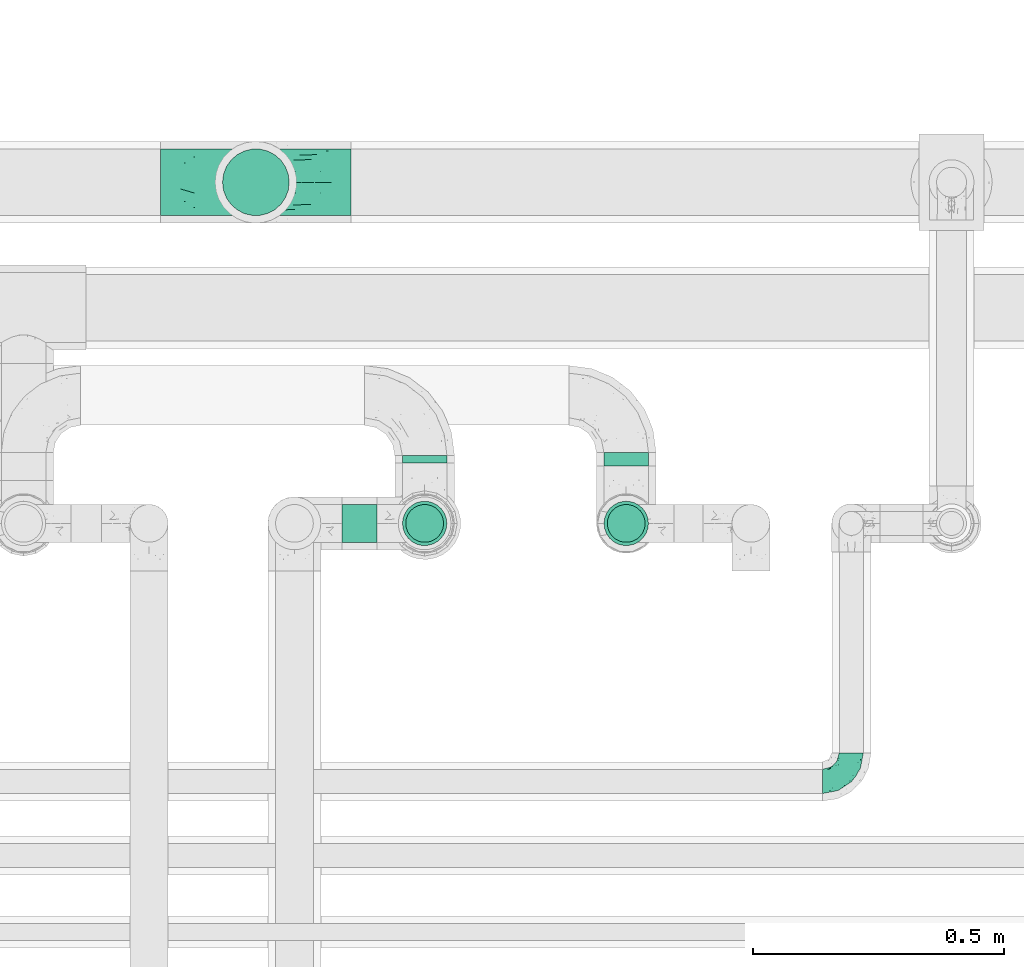
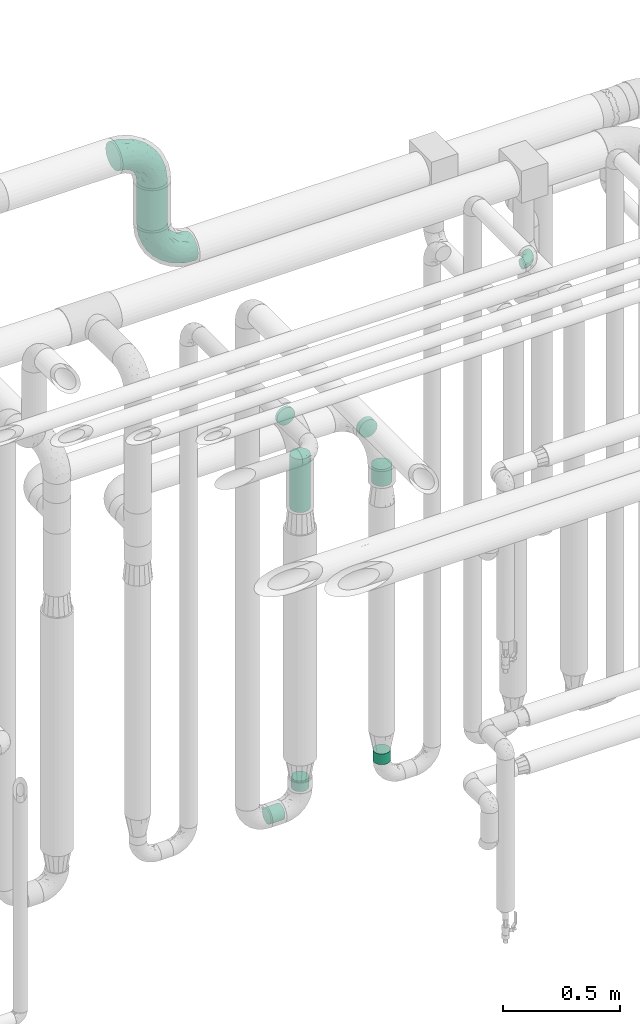
# One storey, part 710 of 827: 8 flow segments, 3 flow fittings.
"""IFC2X3 building model written with IfcOpenShell, lengths in millimetres."""

from ifc_helpers import new_model, entity, si_unit, converted_unit, derived_unit, direction, frame, origin, origin_2d_with_axis, place, context, subcontext, project, spatial, circle, extrude, faceted_brep, source, transform, mapped, material, type_object, type_shapes, element, save


model = new_model("IFC2X3")

# Units and contexts
model_context = context("Model", 3, precision=0.01, world=origin(), true_north=direction((6.12303176911189e-17, 1.0)))
body_context = subcontext(model_context, "Body", "Model", "MODEL_VIEW")
ifc_project = project(units=[si_unit("LENGTHUNIT", "METRE", prefix="MILLI"), si_unit("AREAUNIT", "SQUARE_METRE"), si_unit("VOLUMEUNIT", "CUBIC_METRE"), converted_unit("PLANEANGLEUNIT", "DEGREE", entity("IfcRatioMeasure", 0.0174532925199433), si_unit("PLANEANGLEUNIT", "RADIAN"), dimensions=[0, 0, 0, 0, 0, 0, 0]), si_unit("MASSUNIT", "GRAM", prefix="KILO"), derived_unit("MASSDENSITYUNIT", [(si_unit("MASSUNIT", "GRAM", prefix="KILO"), 1), (si_unit("LENGTHUNIT", "METRE"), -3)]), derived_unit("MOMENTOFINERTIAUNIT", [(si_unit("LENGTHUNIT", "METRE"), 4)]), si_unit("TIMEUNIT", "SECOND"), si_unit("FREQUENCYUNIT", "HERTZ"), si_unit("THERMODYNAMICTEMPERATUREUNIT", "DEGREE_CELSIUS"), derived_unit("THERMALTRANSMITTANCEUNIT", [(si_unit("MASSUNIT", "GRAM", prefix="KILO"), 1), (si_unit("THERMODYNAMICTEMPERATUREUNIT", "KELVIN"), -1), (si_unit("TIMEUNIT", "SECOND"), -3)]), derived_unit("VOLUMETRICFLOWRATEUNIT", [(si_unit("LENGTHUNIT", "METRE"), 3), (si_unit("TIMEUNIT", "SECOND"), -1)]), derived_unit("MASSFLOWRATEUNIT", [(si_unit("MASSUNIT", "GRAM", prefix="KILO"), 1), (si_unit("TIMEUNIT", "SECOND"), -1)]), derived_unit("ROTATIONALFREQUENCYUNIT", [(si_unit("TIMEUNIT", "SECOND"), -1)]), si_unit("ELECTRICCURRENTUNIT", "AMPERE"), si_unit("ELECTRICVOLTAGEUNIT", "VOLT"), si_unit("POWERUNIT", "WATT"), si_unit("FORCEUNIT", "NEWTON", prefix="KILO"), si_unit("ILLUMINANCEUNIT", "LUX"), si_unit("LUMINOUSFLUXUNIT", "LUMEN"), si_unit("LUMINOUSINTENSITYUNIT", "CANDELA"), derived_unit("USERDEFINED", [(si_unit("MASSUNIT", "GRAM", prefix="KILO"), -1), (si_unit("LENGTHUNIT", "METRE"), -2), (si_unit("TIMEUNIT", "SECOND"), 3), (si_unit("LUMINOUSFLUXUNIT", "LUMEN"), 1)]), derived_unit("LINEARVELOCITYUNIT", [(si_unit("LENGTHUNIT", "METRE"), 1), (si_unit("TIMEUNIT", "SECOND"), -1)]), si_unit("PRESSUREUNIT", "PASCAL"), derived_unit("USERDEFINED", [(si_unit("LENGTHUNIT", "METRE"), -2), (si_unit("MASSUNIT", "GRAM", prefix="KILO"), 1), (si_unit("TIMEUNIT", "SECOND"), -2)]), derived_unit("LINEARFORCEUNIT", [(si_unit("MASSUNIT", "GRAM", prefix="KILO"), 1), (si_unit("LENGTHUNIT", "METRE"), 1), (si_unit("TIMEUNIT", "SECOND"), -2), (si_unit("LENGTHUNIT", "METRE"), -1)]), derived_unit("PLANARFORCEUNIT", [(si_unit("MASSUNIT", "GRAM", prefix="KILO"), 1), (si_unit("LENGTHUNIT", "METRE"), 1), (si_unit("TIMEUNIT", "SECOND"), -2), (si_unit("LENGTHUNIT", "METRE"), -2)])], contexts=[model_context])

# Site, building, storey
site_placement = place(None, origin())
site = spatial("IfcSite", under=ifc_project, at=site_placement, CompositionType="ELEMENT")
building_placement = place(site_placement, origin())
building = spatial("IfcBuilding", under=site, at=building_placement, CompositionType="ELEMENT")
storey_placement = place(building_placement, frame((0.0, 0.0, 28200.0)))
storey = spatial("IfcBuildingStorey", under=building, at=storey_placement, Name="08", CompositionType="ELEMENT", Elevation=28200.0)

# Flow segments
pipe_segment_type_1 = type_object("IfcPipeSegmentType", PredefinedType="NOTDEFINED")
flow_segment_1_placement = place(storey_placement, frame((57842.95, 18112.0, 3090.0)))
element("IfcFlowSegment", 1, at=flow_segment_1_placement, inside=storey, type_object=pipe_segment_type_1, context=body_context, shape_type="SweptSolid", body=[
    extrude(circle(Radius=66.5, at=origin_2d_with_axis()), frame((68.1, 68.1, 0.0), z_axis=(0.0, 0.0, 1.0), x_axis=(-1.0, 0.0, 0.0)), (0.0, 0.0, 1.0), 219.743188805708),
])
pipe_segment_type_2 = type_object("IfcPipeSegmentType", PredefinedType="NOTDEFINED")
flow_segment_2_placement = place(storey_placement, frame((58201.72, 17620.0, 2254.15)))
element("IfcFlowSegment", 2, at=flow_segment_2_placement, inside=storey, type_object=pipe_segment_type_2, context=body_context, shape_type="SweptSolid", body=[
    extrude(circle(Radius=44.25, at=origin_2d_with_axis()), frame((45.85, 0.0, 45.85), z_axis=(0.0, 1.0, 0.0), x_axis=(-1.0, 0.0, 0.0)), (0.0, 0.0, 1.0), 15.0961141089939),
])
flow_segment_3_placement = place(storey_placement, frame((58201.72, 17454.15, 1902.45)))
element("IfcFlowSegment", 3, at=flow_segment_3_placement, inside=storey, type_object=pipe_segment_type_2, context=body_context, shape_type="SweptSolid", body=[
    extrude(circle(Radius=44.25, at=origin_2d_with_axis()), frame((45.85, 45.85, 0.0)), (0.0, 0.0, 1.0), 277.547222472813),
])
flow_segment_4_placement = place(storey_placement, frame((58082.89, 17460.65, 310.65)))
element("IfcFlowSegment", 4, at=flow_segment_4_placement, inside=storey, type_object=pipe_segment_type_2, context=body_context, shape_type="SweptSolid", body=[
    extrude(circle(Radius=37.75, at=origin_2d_with_axis()), frame((0.0, 39.35, 39.35), z_axis=(1.0, 0.0, 0.0), x_axis=(0.0, -1.0, 0.0)), (0.0, 0.0, 1.0), 69.6845769329227),
])
for number, where in (
    (5, (58208.22, 17460.65, 445.0)),
    (6, (58610.04, 17460.65, 445.0)),
):
    element("IfcFlowSegment", number, at=place(storey_placement, frame(where)), inside=storey, type_object=pipe_segment_type_2, context=body_context, shape_type="SweptSolid", body=[
        extrude(circle(Radius=37.75, at=origin_2d_with_axis()), frame((39.35, 39.35, 0.0), z_axis=(0.0, 0.0, 1.0), x_axis=(-1.0, 0.0, 0.0)), (0.0, 0.0, 1.0), 55.0000000000005),
    ])
flow_segment_5_placement = place(storey_placement, frame((58603.54, 17614.0, 2054.15)))
element("IfcFlowSegment", 7, at=flow_segment_5_placement, inside=storey, type_object=pipe_segment_type_2, context=body_context, shape_type="SweptSolid", body=[
    extrude(circle(Radius=44.25, at=origin_2d_with_axis()), frame((45.85, 0.0, 45.85), z_axis=(0.0, 1.0, 0.0), x_axis=(-1.0, 0.0, 0.0)), (0.0, 0.0, 1.0), 27.0961141089868),
])
flow_segment_6_placement = place(storey_placement, frame((58603.54, 17454.15, 1898.17)))
element("IfcFlowSegment", 8, at=flow_segment_6_placement, inside=storey, type_object=pipe_segment_type_2, context=body_context, shape_type="SweptSolid", body=[
    extrude(circle(Radius=44.25, at=origin_2d_with_axis()), frame((45.85, 45.85, 0.0)), (0.0, 0.0, 1.0), 87.8307333425285),
])

# Flow fittings
ifc_material = material()
pipe_fitting_type_1 = type_object("IfcPipeFittingType", Name="ADSK_2", PredefinedType="NOTDEFINED", material=ifc_material)
shared_shape_1 = source(origin(), body_context, "Body", "Brep", [
    faceted_brep([(-190.0, 33.25, -57.59), (-190.0, 17.21, -64.23), (-190.0, 0.0, -66.5), (-190.0, -17.21, -64.23), (-190.0, -33.25, -57.59), (-190.0, -47.02, -47.02), (-190.0, -57.59, -33.25), (-190.0, -64.23, -17.21), (-190.0, -66.5, 0.0), (-190.0, -64.23, 17.21), (-190.0, -57.59, 33.25), (-190.0, -47.02, 47.02), (-190.0, -33.25, 57.59), (-190.0, -17.21, 64.23), (-190.0, 0.0, 66.5), (-190.0, 17.21, 64.23), (-190.0, 33.25, 57.59), (-190.0, 47.02, 47.02), (-190.0, 57.59, 33.25), (-190.0, 64.23, 17.21), (-190.0, 66.5, 0.0), (-190.0, 64.23, -17.21), (-190.0, 57.59, -33.25), (-190.0, 47.02, -47.02), (0.0, 190.0, -66.5), (-17.21, 190.0, -64.23), (-33.25, 190.0, -57.59), (-47.02, 190.0, -47.02), (-57.59, 190.0, -33.25), (-64.23, 190.0, -17.21), (-66.5, 190.0, 0.0), (-64.23, 190.0, 17.21), (-57.59, 190.0, 33.25), (-47.02, 190.0, 47.02), (-33.25, 190.0, 57.59), (-17.21, 190.0, 64.23), (0.0, 190.0, 66.5), (17.21, 190.0, 64.23), (33.25, 190.0, 57.59), (47.02, 190.0, 47.02), (57.59, 190.0, 33.25), (64.23, 190.0, 17.21), (66.5, 190.0, 0.0), (64.23, 190.0, -17.21), (57.59, 190.0, -33.25), (47.02, 190.0, -47.02), (33.25, 190.0, -57.59), (17.21, 190.0, -64.23), (-28.55, 147.02, 62.42), (-13.57, 135.63, 66.28), (-140.38, -49.33, 38.23), (-80.14, -30.55, 35.23), (-124.14, -33.9, 50.4), (-141.11, -22.46, 60.31), (-81.84, -6.19, 57.13), (-101.3, 6.38, 65.03), (-125.04, -54.28, 21.95), (-139.96, -61.57, 0.0), (-30.59, -6.47, 21.28), (-47.5, -23.27, 0.0), (-8.63, 8.63, 0.0), (-101.64, 52.37, 61.01), (-147.02, 28.55, 62.42), (-107.01, 35.47, 64.88), (-72.79, -35.94, 16.05), (-91.84, -46.98, 0.0), (-42.05, -7.73, 34.33), (-4.24, 27.9, 35.0), (-46.26, 0.22, 45.96), (-148.38, -6.74, 65.57), (-135.63, 13.57, 66.28), (-58.81, 143.49, 42.9), (-64.43, 158.86, 27.32), (33.87, 124.03, 50.39), (-24.86, 95.88, 66.5), (-6.38, 101.3, 65.03), (-68.44, 29.45, 65.52), (-33.12, 50.38, 63.42), (-47.55, 58.11, 66.37), (-68.78, 157.93, 15.75), (-78.73, 128.81, 21.25), (-145.19, 58.3, 42.81), (-126.57, 73.12, 34.22), (-158.86, 64.43, 27.32), (-157.93, 68.78, 15.75), (-73.06, 126.96, 34.0), (-99.23, 99.23, 24.99), (-94.51, 94.51, 37.44), (-160.28, 41.89, 53.91), (-151.84, 72.54, 0.0), (-128.81, 78.73, 21.25), (-117.41, 90.09, 0.0), (7.42, 29.34, 16.05), (36.05, 72.53, 15.16), (23.27, 47.5, 0.0), (30.73, 80.34, 35.12), (61.57, 139.96, 0.0), (62.07, 150.38, 13.25), (46.98, 91.84, 0.0), (22.46, 141.08, 60.31), (6.16, 81.82, 57.15), (-39.4, 100.2, 64.86), (54.07, 123.33, 21.27), (49.32, 140.35, 38.22), (-83.36, -19.52, 48.87), (6.74, 148.38, 65.57), (-85.07, 81.39, 53.88), (-123.92, 51.92, 55.31), (-90.09, 117.41, 0.0), (-72.54, 151.84, 0.0), (-101.92, 101.92, 11.85), (-42.36, 157.28, 54.02), (-54.08, 118.94, 55.5), (-1.97, 47.81, 48.28), (22.27, 83.36, 46.49), (-79.1, 73.18, 59.88), (-73.69, 63.3, 64.01), (-96.26, 24.55, 66.5), (-73.56, 111.53, 44.32), (-111.08, 72.88, 45.21), (-31.39, 31.39, 56.96), (-71.89, 12.15, 62.21), (-42.48, 117.92, 61.28), (-157.28, 42.36, -54.02), (-72.79, -35.94, -16.05), (-44.48, -10.39, -33.14), (-30.59, -6.47, -21.28), (-101.3, 6.38, -65.03), (-148.38, -6.74, -65.57), (-135.63, 13.57, -66.28), (-157.93, 68.78, -15.75), (-128.81, 78.73, -21.25), (-158.86, 64.43, -27.32), (-147.02, 28.55, -62.42), (-100.2, 39.4, -64.86), (-95.88, 24.86, -66.5), (-150.3, -62.06, -13.27), (-101.92, 101.92, -11.85), (-143.49, 58.81, -42.9), (6.74, 148.38, -65.57), (-13.57, 135.63, -66.28), (-52.37, 101.64, -61.01), (-81.39, 85.07, -53.88), (-51.92, 123.92, -55.31), (-124.14, -33.9, -50.4), (-81.84, -6.19, -57.13), (-78.6, -18.73, -47.44), (-140.38, -49.33, -38.23), (-24.55, 96.26, -66.5), (-35.47, 107.01, -64.88), (-28.55, 147.02, -62.42), (-80.14, -30.55, -35.23), (-123.37, -54.04, -21.36), (-64.43, 158.86, -27.32), (-68.78, 157.93, -15.75), (-73.18, 79.1, -59.88), (-63.3, 73.69, -64.01), (-29.45, 68.44, -65.52), (-50.38, 33.12, -63.42), (-58.11, 47.55, -66.37), (-78.73, 128.81, -21.25), (-99.23, 99.23, -24.99), (-126.96, 73.06, -34.0), (-94.51, 94.51, -37.44), (-58.3, 145.19, -42.81), (-73.12, 126.57, -34.22), (-118.94, 54.08, -55.5), (-41.89, 160.28, -53.91), (22.46, 141.08, -60.31), (6.16, 81.82, -57.15), (-6.38, 101.3, -65.03), (33.87, 124.03, -50.39), (54.35, 125.32, -21.97), (35.86, 72.99, -16.69), (49.34, 140.46, -38.23), (7.54, 29.16, -15.21), (-141.11, -22.46, -60.31), (30.73, 80.34, -35.12), (22.8, 84.14, -46.35), (-4.38, 23.43, -29.89), (5.33, 47.62, -41.81), (-111.53, 73.56, -44.32), (-72.88, 111.08, -45.21), (-48.51, 2.91, -49.35), (-20.15, 28.66, -49.63), (-27.46, 10.86, -41.59), (-12.16, 71.91, -62.22), (2.48, 58.84, -50.8), (-117.92, 42.48, -61.28), (-31.39, 31.39, -56.96)], [[[0, 1, 2, 3, 4, 5, 6, 7, 8, 9, 10, 11, 12, 13, 14, 15, 16, 17, 18, 19, 20, 21, 22, 23]], [[24, 25, 26, 27, 28, 29, 30, 31, 32, 33, 34, 35, 36, 37, 38, 39, 40, 41, 42, 43, 44, 45, 46, 47]], [[35, 48, 49]], [[50, 51, 52]], [[53, 54, 55]], [[56, 10, 9]], [[9, 8, 57]], [[58, 59, 60]], [[56, 50, 10]], [[61, 62, 63]], [[64, 65, 59]], [[58, 64, 59]], [[12, 11, 52]], [[66, 67, 68]], [[52, 53, 12]], [[69, 70, 14]], [[71, 32, 72]], [[73, 39, 38]], [[49, 74, 75]], [[62, 16, 15]], [[14, 70, 15]], [[72, 32, 31]], [[13, 69, 14]], [[76, 77, 78]], [[79, 80, 72]], [[81, 82, 83]], [[62, 15, 70]], [[20, 19, 84]], [[85, 86, 87]], [[81, 17, 88]], [[89, 90, 91]], [[19, 83, 84]], [[16, 88, 17]], [[85, 71, 72]], [[58, 60, 92]], [[49, 36, 35]], [[93, 92, 94]], [[35, 34, 48]], [[92, 93, 95]], [[96, 97, 98]], [[73, 99, 100]], [[49, 101, 74]], [[102, 97, 40]], [[39, 73, 103]], [[95, 102, 103]], [[40, 39, 103]], [[12, 53, 13]], [[68, 54, 104]], [[42, 97, 96]], [[41, 97, 42]], [[99, 38, 37]], [[37, 36, 105]], [[61, 106, 107]], [[108, 80, 109]], [[10, 50, 11]], [[108, 91, 110]], [[109, 79, 30]], [[64, 51, 56]], [[71, 33, 32]], [[86, 110, 90]], [[92, 60, 94]], [[111, 34, 33]], [[71, 112, 111]], [[49, 48, 101]], [[9, 57, 56]], [[17, 81, 18]], [[65, 56, 57]], [[113, 114, 100]], [[75, 105, 49]], [[115, 61, 116]], [[58, 92, 67]], [[99, 73, 38]], [[70, 117, 63]], [[18, 83, 19]], [[71, 85, 118]], [[119, 107, 106]], [[83, 82, 90]], [[51, 50, 56]], [[52, 11, 50]], [[51, 64, 58]], [[56, 65, 64]], [[94, 98, 93]], [[67, 92, 95]], [[95, 114, 113]], [[68, 120, 54]], [[54, 53, 52]], [[69, 53, 55]], [[104, 51, 68]], [[121, 76, 55]], [[103, 73, 114]], [[102, 40, 103]], [[105, 99, 37]], [[75, 77, 100]], [[75, 100, 99]], [[100, 120, 113]], [[111, 48, 34]], [[115, 101, 122]], [[122, 101, 48]], [[101, 116, 78]], [[116, 63, 117]], [[78, 117, 76]], [[63, 62, 70]], [[88, 62, 107]], [[98, 102, 93]], [[95, 93, 102]], [[66, 68, 51]], [[113, 68, 67]], [[49, 105, 36]], [[99, 105, 75]], [[53, 69, 13]], [[70, 69, 55]], [[70, 55, 117]], [[61, 63, 116]], [[76, 117, 55]], [[116, 117, 78]], [[121, 55, 54]], [[76, 121, 77]], [[100, 77, 120]], [[75, 78, 77]], [[54, 120, 121]], [[77, 121, 120]], [[71, 111, 33]], [[111, 112, 122]], [[68, 113, 120]], [[95, 113, 67]], [[61, 115, 106]], [[62, 61, 107]], [[118, 112, 71]], [[119, 87, 82]], [[101, 115, 116]], [[112, 106, 115]], [[79, 72, 31]], [[72, 80, 85]], [[86, 85, 80]], [[118, 85, 87]], [[119, 118, 87]], [[112, 118, 106]], [[30, 79, 31]], [[109, 80, 79]], [[81, 83, 18]], [[84, 83, 90]], [[119, 82, 81]], [[86, 82, 87]], [[107, 119, 81]], [[118, 119, 106]], [[90, 89, 84]], [[20, 84, 89]], [[62, 88, 16]], [[81, 88, 107]], [[101, 78, 74]], [[78, 75, 74]], [[80, 108, 110]], [[82, 86, 90]], [[90, 110, 91]], [[80, 110, 86]], [[40, 97, 41]], [[98, 97, 102]], [[111, 122, 48]], [[115, 122, 112]], [[54, 52, 104]], [[51, 104, 52]], [[51, 58, 66]], [[67, 66, 58]], [[103, 114, 95]], [[100, 114, 73]], [[23, 123, 0]], [[124, 125, 126]], [[127, 128, 129]], [[130, 131, 132]], [[133, 134, 129]], [[129, 135, 127]], [[89, 130, 20]], [[8, 136, 57]], [[91, 131, 89]], [[59, 65, 124]], [[108, 137, 91]], [[132, 22, 21]], [[138, 23, 22]], [[139, 140, 24]], [[141, 142, 143]], [[144, 145, 146]], [[5, 144, 147]], [[140, 148, 149]], [[8, 7, 136]], [[138, 22, 132]], [[6, 5, 147]], [[141, 150, 149]], [[147, 151, 152]], [[152, 136, 6]], [[29, 153, 154]], [[125, 124, 151]], [[136, 65, 57]], [[155, 141, 156]], [[128, 3, 2]], [[126, 59, 124]], [[129, 134, 135]], [[157, 158, 159]], [[160, 161, 137]], [[1, 0, 133]], [[129, 2, 1]], [[162, 138, 132]], [[161, 163, 162]], [[154, 30, 29]], [[144, 5, 4]], [[153, 164, 165]], [[150, 26, 25]], [[166, 123, 138]], [[24, 47, 139]], [[24, 140, 25]], [[28, 153, 29]], [[26, 167, 27]], [[168, 169, 170]], [[140, 150, 25]], [[27, 164, 28]], [[46, 171, 168]], [[172, 98, 173]], [[59, 126, 60]], [[27, 167, 164]], [[44, 174, 45]], [[173, 98, 94]], [[175, 173, 94]], [[176, 144, 4]], [[171, 46, 45]], [[44, 43, 172]], [[43, 96, 172]], [[42, 96, 43]], [[144, 146, 151]], [[144, 176, 145]], [[177, 178, 174]], [[173, 175, 179]], [[44, 172, 174]], [[98, 172, 96]], [[1, 133, 129]], [[179, 180, 177]], [[109, 160, 108]], [[46, 168, 47]], [[176, 4, 3]], [[138, 162, 181]], [[182, 143, 142]], [[153, 165, 160]], [[94, 60, 175]], [[177, 172, 173]], [[151, 147, 144]], [[152, 6, 147]], [[128, 176, 3]], [[127, 158, 145]], [[127, 145, 176]], [[183, 184, 185]], [[65, 152, 124]], [[151, 124, 152]], [[177, 174, 172]], [[171, 45, 174]], [[169, 168, 171]], [[139, 168, 170]], [[178, 177, 180]], [[186, 157, 170]], [[187, 169, 178]], [[126, 179, 175]], [[123, 133, 0]], [[155, 134, 188]], [[188, 134, 133]], [[134, 156, 159]], [[156, 149, 148]], [[159, 148, 157]], [[149, 150, 140]], [[167, 150, 143]], [[60, 126, 175]], [[125, 179, 126]], [[129, 128, 2]], [[176, 128, 127]], [[168, 139, 47]], [[140, 139, 170]], [[140, 170, 148]], [[141, 149, 156]], [[157, 148, 170]], [[156, 148, 159]], [[186, 170, 169]], [[157, 186, 158]], [[145, 158, 189]], [[127, 159, 158]], [[169, 189, 186]], [[158, 186, 189]], [[180, 179, 185]], [[173, 179, 177]], [[187, 184, 189]], [[178, 171, 174]], [[187, 178, 180]], [[169, 171, 178]], [[184, 180, 185]], [[189, 169, 187]], [[138, 123, 23]], [[123, 166, 188]], [[141, 155, 142]], [[150, 141, 143]], [[181, 166, 138]], [[182, 163, 165]], [[134, 155, 156]], [[166, 142, 155]], [[130, 132, 21]], [[132, 131, 162]], [[161, 162, 131]], [[181, 162, 163]], [[182, 181, 163]], [[166, 181, 142]], [[20, 130, 21]], [[89, 131, 130]], [[164, 153, 28]], [[154, 153, 160]], [[182, 165, 164]], [[161, 165, 163]], [[143, 182, 164]], [[181, 182, 142]], [[160, 109, 154]], [[30, 154, 109]], [[150, 167, 26]], [[164, 167, 143]], [[134, 159, 135]], [[159, 127, 135]], [[131, 91, 137]], [[165, 161, 160]], [[160, 137, 108]], [[131, 137, 161]], [[6, 136, 7]], [[65, 136, 152]], [[183, 189, 184]], [[146, 183, 125]], [[146, 125, 151]], [[179, 125, 185]], [[123, 188, 133]], [[155, 188, 166]], [[180, 184, 187]], [[185, 125, 183]], [[146, 145, 183]], [[189, 183, 145]]]),
])
type_shapes(pipe_fitting_type_1, [shared_shape_1])
for number, where, z_axis, x_axis, name in (
    (9, (57911.05, 18180.1, 2900.0), (0.0, 1.0, 0.0), (-1.0, 0.0, 0.0), "ADSK_2"),
    (10, (57911.05, 18180.1, 3499.74), (0.0, -1.0, 0.0), (0.0, 0.0, 1.0), "ADSK_2"),
):
    element("IfcFlowFitting", number, at=place(storey_placement, frame(where, z_axis=z_axis, x_axis=x_axis)), inside=storey, type_object=pipe_fitting_type_1, material=ifc_material, Name=name, ObjectType="ADSK_2", context=body_context, shape_type="MappedRepresentation", body=[
        mapped(shared_shape_1, transform((0.0, 0.0, 0.0), scale=1.0)),
    ])
pipe_fitting_type_2 = type_object("IfcPipeFittingType", Name="ADSK_1", PredefinedType="NOTDEFINED", material=ifc_material)
shared_shape_2 = source(origin(), body_context, "Body", "Brep", [
    faceted_brep([(-57.0, 12.07, -20.91), (-57.0, 6.25, -23.33), (-57.0, 0.0, -24.15), (-57.0, -6.25, -23.33), (-57.0, -12.08, -20.91), (-57.0, -17.08, -17.08), (-57.0, -20.91, -12.08), (-57.0, -23.33, -6.25), (-57.0, -24.15, 0.0), (-57.0, -23.33, 6.25), (-57.0, -20.91, 12.07), (-57.0, -17.08, 17.08), (-57.0, -12.08, 20.91), (-57.0, -6.25, 23.33), (-57.0, 0.0, 24.15), (-57.0, 6.25, 23.33), (-57.0, 12.07, 20.91), (-57.0, 17.08, 17.08), (-57.0, 20.91, 12.07), (-57.0, 23.33, 6.25), (-57.0, 24.15, 0.0), (-57.0, 23.33, -6.25), (-57.0, 20.91, -12.08), (-57.0, 17.08, -17.08), (0.0, 57.0, -24.15), (-6.25, 57.0, -23.33), (-12.07, 57.0, -20.91), (-17.08, 57.0, -17.08), (-20.91, 57.0, -12.08), (-23.33, 57.0, -6.25), (-24.15, 57.0, 0.0), (-23.33, 57.0, 6.25), (-20.91, 57.0, 12.07), (-17.08, 57.0, 17.08), (-12.07, 57.0, 20.91), (-6.25, 57.0, 23.33), (0.0, 57.0, 24.15), (6.25, 57.0, 23.33), (12.08, 57.0, 20.91), (17.08, 57.0, 17.08), (20.91, 57.0, 12.07), (23.33, 57.0, 6.25), (24.15, 57.0, 0.0), (23.33, 57.0, -6.25), (20.91, 57.0, -12.08), (17.08, 57.0, -17.08), (12.08, 57.0, -20.91), (6.25, 57.0, -23.33), (14.9, 21.14, 6.17), (13.61, 24.64, 12.48), (6.23, 8.95, 8.98), (-41.47, -21.06, 0.0), (-41.92, -18.38, 13.72), (-24.64, -13.61, 12.48), (-37.37, -13.24, 18.15), (-6.8, -4.93, 8.18), (-21.76, -15.19, 6.22), (-12.78, -9.18, 0.0), (-37.73, -20.51, 7.75), (-7.38, 7.38, 20.24), (-23.37, -4.26, 20.42), (-11.9, -3.19, 15.86), (-42.14, -8.7, 21.82), (13.24, 37.37, 18.15), (9.33, 23.53, 16.85), (4.26, 23.37, 20.42), (2.77, 10.92, 15.55), (-29.46, 0.91, 23.52), (-44.13, 20.56, 15.69), (-39.25, 26.33, 10.88), (-49.02, 22.92, 9.96), (-34.58, 23.87, 17.15), (-15.8, 6.8, 22.81), (-8.67, 20.47, 23.88), (-18.12, 12.9, 24.08), (-48.29, 14.92, 19.65), (-44.06, -2.85, 23.78), (-9.23, 48.95, 22.58), (-3.78, 42.74, 24.07), (-40.34, 4.26, 24.09), (-44.02, 26.14, 5.46), (-44.04, 9.88, 22.74), (-4.95, 16.87, 22.52), (-2.75, 1.43, 12.5), (-25.48, 40.98, 10.71), (20.51, 37.73, 7.75), (18.38, 41.92, 13.72), (8.7, 42.14, 21.82), (-25.95, -17.97, 0.0), (2.85, 44.06, 23.78), (21.06, 41.47, 0.0), (17.97, 25.95, 0.0), (-24.04, -9.27, 17.13), (-33.26, 33.26, 5.86), (-28.55, 40.57, 0.0), (-40.57, 28.55, 0.0), (-25.29, 47.19, 4.06), (-27.01, 31.1, 16.77), (-15.7, 43.95, 19.9), (-20.27, 45.22, 15.61), (-30.53, 31.98, 12.64), (-11.28, 38.33, 22.92), (-9.97, 27.88, 24.09), (-20.15, 30.26, 21.25), (-31.25, 11.75, 23.64), (-28.75, 7.23, 24.15), (-29.53, 18.06, 22.27), (-28.44, 24.21, 20.02), (-37.55, 17.7, 20.26), (-15.88, 29.25, 22.99), (-20.82, 20.82, 23.44), (-0.91, 29.46, 23.52), (-13.5, -7.67, 12.04), (1.49, 1.56, 5.16), (8.86, 10.35, 4.59), (0.38, -0.38, 0.0), (9.18, 12.78, 0.0), (-37.37, -13.24, -18.15), (8.86, 10.35, -4.59), (-45.22, 20.27, -15.61), (-43.95, 15.7, -19.9), (-38.33, 11.28, -22.92), (-48.95, 9.23, -22.58), (-47.19, 25.29, -4.06), (-33.26, 33.26, -5.86), (18.38, 41.92, -13.72), (-30.26, 20.15, -21.25), (2.85, 44.06, -23.78), (-4.26, 40.34, -24.09), (-40.98, 25.48, -10.71), (-41.92, -18.38, -13.72), (9.25, 23.5, -16.92), (4.26, 23.37, -20.42), (13.24, 37.37, -18.15), (-37.73, -20.51, -7.75), (-11.75, 31.25, -23.64), (-7.23, 28.75, -24.15), (-12.9, 18.12, -24.08), (8.7, 42.14, -21.82), (-44.06, -2.85, -23.78), (-6.8, 15.8, -22.81), (-20.47, 8.67, -23.88), (-24.64, -13.61, -12.48), (-42.74, 3.78, -24.07), (-18.06, 29.53, -22.27), (-24.21, 28.44, -20.02), (-27.88, 9.97, -24.09), (-31.1, 27.01, -16.77), (-26.14, 44.02, -5.46), (14.9, 21.14, -6.17), (20.51, 37.73, -7.75), (-9.88, 44.04, -22.74), (-20.56, 44.13, -15.69), (-21.76, -15.19, -6.22), (-13.5, -7.67, -12.04), (-24.14, -9.76, -16.74), (-11.9, -3.19, -15.86), (-14.92, 48.29, -19.65), (-23.37, -4.26, -20.42), (-0.91, 29.46, -23.52), (-26.33, 39.25, -10.88), (-23.87, 34.58, -17.15), (-42.14, -8.7, -21.82), (-22.92, 49.02, -9.96), (13.61, 24.64, -12.48), (-31.98, 30.53, -12.64), (-16.87, 4.95, -22.52), (-17.7, 37.55, -20.26), (-29.25, 15.88, -22.99), (-20.82, 20.82, -23.44), (-29.46, 0.91, -23.52), (-7.38, 7.38, -20.24), (2.77, 10.92, -15.55), (6.23, 8.95, -8.98), (-6.8, -4.93, -8.18), (-2.81, 1.41, -12.54), (1.49, 1.56, -5.16)], [[[0, 1, 2, 3, 4, 5, 6, 7, 8, 9, 10, 11, 12, 13, 14, 15, 16, 17, 18, 19, 20, 21, 22, 23]], [[24, 25, 26, 27, 28, 29, 30, 31, 32, 33, 34, 35, 36, 37, 38, 39, 40, 41, 42, 43, 44, 45, 46, 47]], [[48, 49, 50]], [[9, 8, 51]], [[52, 53, 54]], [[55, 56, 57]], [[10, 58, 52]], [[9, 58, 10]], [[59, 60, 61]], [[54, 12, 11]], [[54, 62, 12]], [[63, 39, 38]], [[64, 65, 66]], [[62, 60, 67]], [[68, 69, 70]], [[71, 69, 68]], [[72, 73, 74]], [[16, 75, 17]], [[13, 76, 14]], [[35, 77, 78]], [[14, 79, 15]], [[17, 68, 18]], [[14, 76, 79]], [[20, 19, 80]], [[70, 19, 18]], [[81, 15, 79]], [[15, 81, 16]], [[73, 72, 82]], [[66, 83, 50]], [[32, 31, 84]], [[85, 86, 49]], [[63, 87, 65]], [[56, 58, 88]], [[36, 89, 37]], [[85, 41, 40]], [[36, 35, 78]], [[90, 41, 85]], [[40, 39, 86]], [[12, 62, 13]], [[86, 85, 40]], [[48, 85, 49]], [[85, 91, 90]], [[87, 38, 37]], [[92, 60, 54]], [[80, 69, 93]], [[93, 94, 95]], [[10, 52, 11]], [[94, 96, 30]], [[97, 98, 99]], [[80, 93, 95]], [[100, 97, 84]], [[99, 98, 33]], [[101, 102, 78]], [[103, 101, 98]], [[96, 31, 30]], [[77, 98, 101]], [[77, 35, 34]], [[34, 33, 98]], [[9, 51, 58]], [[87, 63, 38]], [[104, 105, 74]], [[106, 103, 107]], [[106, 81, 104]], [[75, 68, 17]], [[108, 107, 71]], [[33, 32, 99]], [[109, 103, 110]], [[101, 109, 102]], [[89, 78, 111]], [[53, 52, 58]], [[54, 11, 52]], [[60, 62, 54]], [[88, 58, 51]], [[76, 62, 67]], [[53, 112, 92]], [[60, 59, 72]], [[39, 63, 86]], [[49, 86, 63]], [[89, 87, 37]], [[42, 41, 90]], [[111, 82, 65]], [[111, 65, 87]], [[65, 59, 66]], [[104, 81, 79]], [[75, 81, 108]], [[32, 84, 99]], [[97, 99, 84]], [[98, 97, 103]], [[106, 107, 108]], [[74, 102, 110]], [[111, 78, 102]], [[74, 110, 104]], [[74, 67, 72]], [[61, 92, 112]], [[66, 59, 61]], [[56, 53, 58]], [[66, 50, 49]], [[61, 112, 83]], [[66, 49, 64]], [[78, 89, 36]], [[87, 89, 111]], [[62, 76, 13]], [[79, 76, 67]], [[100, 93, 69]], [[96, 93, 84]], [[55, 113, 50]], [[113, 114, 50]], [[104, 79, 105]], [[106, 104, 110]], [[20, 80, 95]], [[85, 48, 91]], [[115, 114, 113]], [[116, 91, 48]], [[70, 80, 19]], [[93, 96, 94]], [[84, 31, 96]], [[103, 106, 110]], [[81, 106, 108]], [[103, 97, 107]], [[71, 107, 97]], [[71, 97, 100]], [[108, 71, 68]], [[79, 67, 105]], [[67, 74, 105]], [[115, 113, 57]], [[112, 56, 55]], [[56, 88, 57]], [[60, 72, 67]], [[82, 72, 59]], [[65, 82, 59]], [[82, 111, 73]], [[111, 102, 73]], [[102, 74, 73]], [[81, 75, 16]], [[68, 75, 108]], [[68, 70, 18]], [[80, 70, 69]], [[98, 77, 34]], [[78, 77, 101]], [[93, 100, 84]], [[71, 100, 69]], [[102, 109, 110]], [[101, 103, 109]], [[53, 92, 54]], [[61, 60, 92]], [[56, 112, 53]], [[83, 112, 55]], [[50, 83, 55]], [[61, 83, 66]], [[49, 63, 64]], [[65, 64, 63]], [[57, 113, 55]], [[114, 115, 116]], [[116, 48, 114]], [[48, 50, 114]], [[117, 5, 4]], [[116, 115, 118]], [[119, 120, 23]], [[121, 122, 120]], [[95, 123, 20]], [[0, 23, 120]], [[124, 95, 94]], [[125, 45, 44]], [[121, 120, 126]], [[24, 127, 128]], [[22, 21, 129]], [[0, 122, 1]], [[5, 117, 130]], [[131, 132, 133]], [[134, 88, 51]], [[135, 136, 137]], [[6, 5, 130]], [[46, 138, 47]], [[139, 3, 2]], [[140, 141, 137]], [[6, 134, 7]], [[134, 130, 142]], [[143, 2, 1]], [[144, 126, 145]], [[121, 146, 143]], [[147, 120, 119]], [[94, 148, 124]], [[149, 150, 91]], [[30, 29, 148]], [[151, 25, 128]], [[27, 152, 28]], [[134, 153, 88]], [[154, 155, 156]], [[27, 26, 157]], [[151, 26, 25]], [[155, 158, 156]], [[24, 47, 127]], [[1, 122, 143]], [[138, 132, 159]], [[160, 152, 161]], [[24, 128, 25]], [[46, 133, 138]], [[162, 117, 4]], [[148, 160, 124]], [[152, 160, 163]], [[154, 142, 155]], [[45, 125, 133]], [[133, 46, 45]], [[125, 164, 133]], [[51, 7, 134]], [[42, 90, 43]], [[165, 147, 129]], [[153, 134, 142]], [[43, 150, 44]], [[162, 4, 3]], [[141, 140, 166]], [[117, 162, 158]], [[163, 29, 28]], [[43, 90, 150]], [[123, 21, 20]], [[144, 151, 135]], [[157, 152, 27]], [[167, 145, 161]], [[23, 22, 119]], [[168, 126, 169]], [[121, 168, 146]], [[139, 143, 170]], [[142, 130, 117]], [[8, 7, 51]], [[134, 6, 130]], [[139, 162, 3]], [[170, 166, 158]], [[170, 158, 162]], [[158, 171, 156]], [[44, 150, 125]], [[91, 150, 90]], [[164, 125, 150]], [[132, 138, 133]], [[127, 138, 159]], [[131, 164, 172]], [[132, 171, 140]], [[135, 151, 128]], [[157, 151, 167]], [[22, 129, 119]], [[147, 119, 129]], [[120, 147, 126]], [[144, 145, 167]], [[137, 146, 169]], [[170, 143, 146]], [[137, 169, 135]], [[137, 159, 140]], [[171, 172, 156]], [[173, 174, 175]], [[156, 175, 154]], [[174, 57, 153]], [[132, 172, 171]], [[172, 164, 173]], [[143, 139, 2]], [[162, 139, 170]], [[138, 127, 47]], [[128, 127, 159]], [[165, 124, 160]], [[123, 124, 129]], [[149, 173, 164]], [[176, 174, 173]], [[135, 128, 136]], [[144, 135, 169]], [[150, 149, 164]], [[176, 118, 115]], [[149, 91, 116]], [[30, 148, 94]], [[163, 148, 29]], [[124, 123, 95]], [[129, 21, 123]], [[126, 144, 169]], [[151, 144, 167]], [[126, 147, 145]], [[161, 145, 147]], [[161, 147, 165]], [[167, 161, 152]], [[128, 159, 136]], [[159, 137, 136]], [[154, 153, 142]], [[132, 140, 159]], [[174, 176, 57]], [[57, 88, 153]], [[166, 140, 171]], [[158, 166, 171]], [[166, 170, 141]], [[170, 146, 141]], [[146, 137, 141]], [[151, 157, 26]], [[152, 157, 167]], [[152, 163, 28]], [[148, 163, 160]], [[120, 122, 0]], [[143, 122, 121]], [[124, 165, 129]], [[161, 165, 160]], [[146, 168, 169]], [[121, 126, 168]], [[142, 117, 155]], [[158, 155, 117]], [[175, 156, 172]], [[153, 154, 174]], [[173, 175, 172]], [[174, 154, 175]], [[164, 131, 133]], [[172, 132, 131]], [[176, 173, 118]], [[57, 176, 115]], [[173, 149, 118]], [[149, 116, 118]]]),
])
type_shapes(pipe_fitting_type_2, [shared_shape_2])
flow_fitting_placement = place(storey_placement, frame((59098.13, 16985.69, 3200.0)))
element("IfcFlowFitting", 11, at=flow_fitting_placement, inside=storey, type_object=pipe_fitting_type_2, material=ifc_material, Name="ADSK_1", ObjectType="ADSK_1", context=body_context, shape_type="MappedRepresentation", body=[
    mapped(shared_shape_2, transform((0.0, 0.0, 0.0), scale=1.0)),
])

save(model, "model.ifc")
